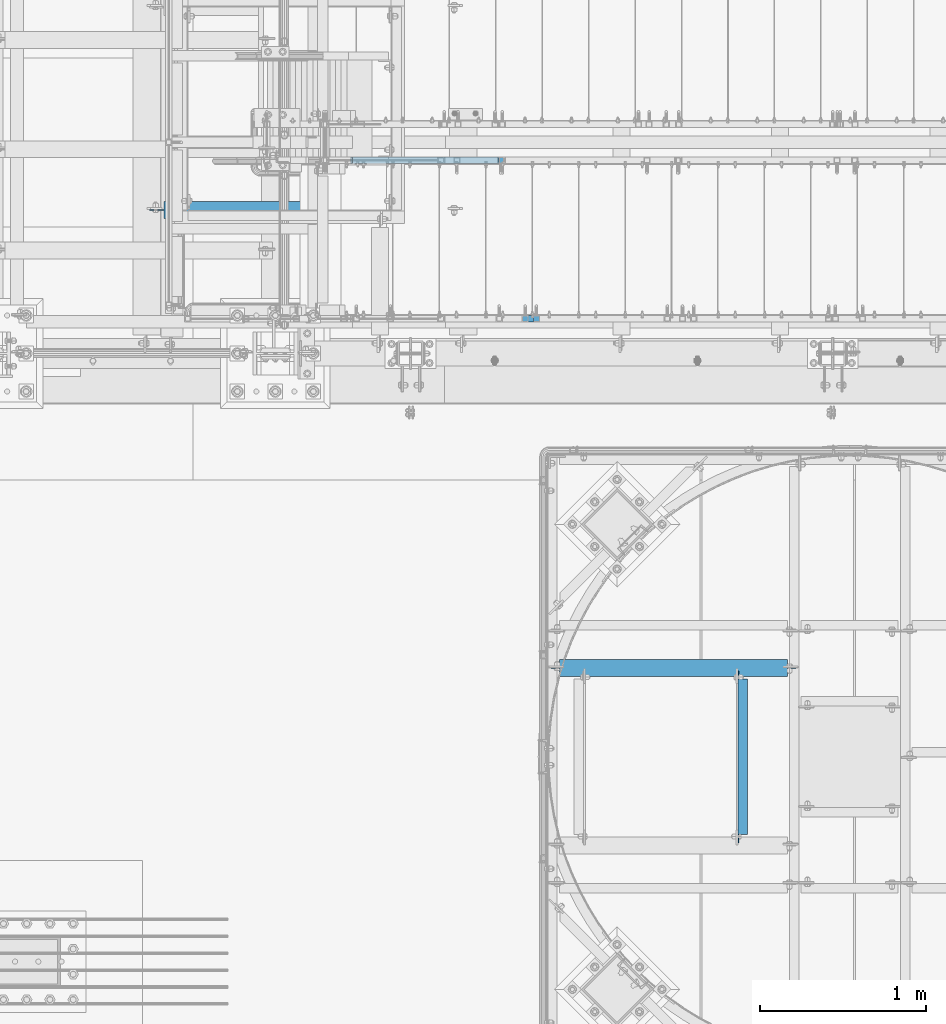
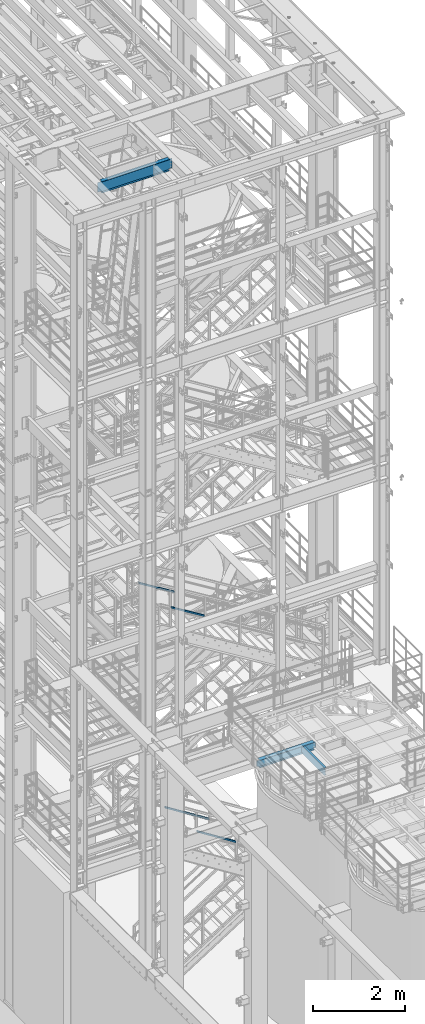
# One storey, part 937 of 1876: 4 members, 3 beams, 7 elements without a shape of their own.
"""IFC2X3 building model written with IfcOpenShell, lengths in millimetres."""

import ifcopenshell
import ifcopenshell.guid

model = None  # the IFC model being written
_history = None  # IfcOwnerHistory: only IFC2X3 demands one
_inside = {}  # id of a spatial element -> (the spatial element, [elements in it])
_under = {}  # id of a project, library or spatial element -> (it, [spatial elements below it])
_declared = {}  # id of a project -> (the project, [libraries it declares])
_typed = {}  # id of a type object -> (the type object, [elements of that type])
_made_of = {}  # id of a material, layer set ... -> (it, [elements and type objects made of it])


def new_model(schema):
    """Start an empty IFC model of exactly this schema.

    Asked for "IFC4X3", IfcOpenShell would pick the latest addendum, in which some entities
    have other attributes; the version numbers below select the first issue.
    IFC2X3 requires an IfcOwnerHistory on every rooted entity: one is made here for all.
    """
    global model, _history
    if schema == "IFC4X3":
        model = ifcopenshell.file(schema_version=(4, 3, 0, 0))
    else:
        model = ifcopenshell.file(schema=schema)
    _inside.clear()
    _under.clear()
    _declared.clear()
    _typed.clear()
    _made_of.clear()
    _history = None
    if model.schema == "IFC2X3":
        org = make("IfcOrganization", Name="unknown")
        user = make(
            "IfcPersonAndOrganization",
            ThePerson=make("IfcPerson", FamilyName="unknown"),
            TheOrganization=org,
        )
        app = make(
            "IfcApplication",
            ApplicationDeveloper=org,
            Version="unknown",
            ApplicationFullName="unknown",
            ApplicationIdentifier="unknown",
        )
        _history = make(
            "IfcOwnerHistory",
            OwningUser=user,
            OwningApplication=app,
            ChangeAction="ADDED",
            CreationDate=0,
        )
    return model


def make(cls, **values):
    """One entity of the class cls with the attributes given. An attribute that is None is left unset."""
    return model.create_entity(
        cls, **{name: value for name, value in values.items() if value is not None}
    )


def rooted(cls, **values):
    """An entity with a GlobalId (a new one), such as an element, a storey or a relation."""
    return make(cls, GlobalId=ifcopenshell.guid.new(), OwnerHistory=_history, **values)


def si_unit(unit_type, name, prefix=None):
    """IfcSIUnit, for example si_unit("LENGTHUNIT", "METRE", prefix="MILLI")."""
    return make("IfcSIUnit", UnitType=unit_type, Prefix=prefix, Name=name)


def assignment(units):
    """IfcUnitAssignment: the units of a project."""
    return None if units is None else make("IfcUnitAssignment", Units=units)


def point(xyz):
    """IfcCartesianPoint."""
    return None if xyz is None else make("IfcCartesianPoint", Coordinates=xyz)


def direction(xyz):
    """IfcDirection."""
    return None if xyz is None else make("IfcDirection", DirectionRatios=xyz)


def frame(location, z_axis=None, x_axis=None):
    """IfcAxis2Placement3D, a coordinate frame: its origin and axes. An axis left out is left unset."""
    return make(
        "IfcAxis2Placement3D",
        Location=point(location),
        Axis=direction(z_axis),
        RefDirection=direction(x_axis),
    )


def origin_with_axes():
    """The frame at (0, 0, 0) with the z axis (0, 0, 1) and the x axis (1, 0, 0) written out."""
    return frame((0.0, 0.0, 0.0), z_axis=(0.0, 0.0, 1.0), x_axis=(1.0, 0.0, 0.0))


def place(relative_to, where):
    """IfcLocalPlacement: puts the frame where relative to a parent placement (None: the world)."""
    return make(
        "IfcLocalPlacement", PlacementRelTo=relative_to, RelativePlacement=where
    )


def context(
    kind, dimensions, precision=None, world=None, true_north=None, identifier=None
):
    """IfcGeometricRepresentationContext, for example the 3D "Model" context."""
    return make(
        "IfcGeometricRepresentationContext",
        ContextIdentifier=identifier,
        ContextType=kind,
        CoordinateSpaceDimension=dimensions,
        Precision=precision,
        WorldCoordinateSystem=world,
        TrueNorth=true_north,
    )


def subcontext(parent, identifier, kind, view, scale=None):
    """IfcGeometricRepresentationSubContext, for example "Body" below "Model"."""
    return make(
        "IfcGeometricRepresentationSubContext",
        ContextIdentifier=identifier,
        ContextType=kind,
        ParentContext=parent,
        TargetScale=scale,
        TargetView=view,
    )


def project(units=None, contexts=None):
    """IfcProject with its units and contexts."""
    return rooted(
        "IfcProject",
        Name="project",
        RepresentationContexts=contexts,
        UnitsInContext=assignment(units),
    )


def spatial(cls, under=None, at=None, **own):
    """A site, building, storey or space (cls), placed at a placement, below another one or the project."""
    s = rooted(cls, ObjectPlacement=at, **own)
    if under is not None:
        _under.setdefault(under.id(), (under, []))[1].append(s)
    return s


def faces_of(points, faces, orient=None, outer=None):
    """IfcFace entities. A face is a list of loops; a loop is a list of indices into points, from 0.

    orient and outer hold one flag for each loop. By default every Orientation is true, the
    first loop of a face is its IfcFaceOuterBound and the others are IfcFaceBound.
    """
    made = []
    for i, loops in enumerate(faces):
        bounds = []
        for j, loop in enumerate(loops):
            is_outer = j == 0 if outer is None else outer[i][j]
            bounds.append(
                make(
                    "IfcFaceOuterBound" if is_outer else "IfcFaceBound",
                    Bound=make("IfcPolyLoop", Polygon=[points[k] for k in loop]),
                    Orientation=True if orient is None else orient[i][j],
                )
            )
        made.append(make("IfcFace", Bounds=bounds))
    return made


def faceted_brep(points, faces, orient=None, outer=None, voids=None):
    """IfcFacetedBrep: a solid bounded by flat faces; with voids (closed shells), ...WithVoids."""
    shared = [point(p) for p in points]
    hull = make("IfcClosedShell", CfsFaces=faces_of(shared, faces, orient, outer))
    if voids is None:
        return make("IfcFacetedBrep", Outer=hull)
    return make(
        "IfcFacetedBrepWithVoids",
        Outer=hull,
        Voids=[
            make(cls, CfsFaces=faces_of(shared, fs, o, b)) for cls, fs, o, b in voids
        ],
    )


def shape(context_of_items, identifier, shape_type, items):
    """IfcShapeRepresentation: the items that make up one representation, for example the "Body"."""
    return make(
        "IfcShapeRepresentation",
        ContextOfItems=context_of_items,
        RepresentationIdentifier=identifier,
        RepresentationType=shape_type,
        Items=items,
    )


def material(Name=None, Category=None):
    """IfcMaterial."""
    return make("IfcMaterial", Name=Name, Category=Category)


def made_of(thing, what):
    """Note that an element or type object is made of a material, layer set ...; save() writes the relation."""
    if what is not None:
        _made_of.setdefault(what.id(), (what, []))[1].append(thing)
    return thing


def type_object(cls, material=None, **own):
    """A type object (cls), such as IfcWallType, which elements share."""
    return made_of(rooted(cls, **own), material)


def element(
    cls,
    number,
    at=None,
    inside=None,
    cuts=None,
    type_object=None,
    material=None,
    context=None,
    identifier="Body",
    shape_type=None,
    held_by="IfcProductDefinitionShape",
    body=None,
    shapes=None,
    **own,
):
    """One element of the class cls, such as IfcWall. Its Tag is "e" and its number.

    at: its placement. inside: the storey or other place that contains it. cuts: it is an
    opening in that element (IfcRelVoidsElement). A single representation is given by context,
    identifier, shape_type and body (its items); several are given by shapes. held_by: the class
    of the entity that holds the representations. save() writes the other relations.
    """
    e = rooted(cls, Tag="e%d" % number, ObjectPlacement=at, **own)
    if body is not None:
        shapes = [shape(context, identifier, shape_type, body)]
    if shapes is not None:
        e.Representation = make(held_by, Representations=shapes)
    if inside is not None:
        _inside.setdefault(inside.id(), (inside, []))[1].append(e)
    if cuts is not None:
        rooted(
            "IfcRelVoidsElement", RelatingBuildingElement=cuts, RelatedOpeningElement=e
        )
    if type_object is not None:
        _typed.setdefault(type_object.id(), (type_object, []))[1].append(e)
    return made_of(e, material)


def aggregate(whole, parts):
    """IfcRelAggregates: a whole, such as a stair, and the parts it consists of."""
    return rooted("IfcRelAggregates", RelatingObject=whole, RelatedObjects=parts)


def save(model, path):
    """Write the relations noted so far, then the file.

    IfcRelAggregates (storeys below a building ...), IfcRelContainedInSpatialStructure (elements
    in a storey), IfcRelDefinesByType, IfcRelAssociatesMaterial and IfcRelDeclares: one each for
    every whole, place, type object, material and project.
    """
    for whole, parts in _under.values():
        aggregate(whole, parts)
    for where, things in _inside.values():
        rooted(
            "IfcRelContainedInSpatialStructure",
            RelatedElements=things,
            RelatingStructure=where,
        )
    for kind, things in _typed.values():
        rooted("IfcRelDefinesByType", RelatedObjects=things, RelatingType=kind)
    for what, things in _made_of.values():
        rooted("IfcRelAssociatesMaterial", RelatedObjects=things, RelatingMaterial=what)
    for by, libraries in _declared.values():
        rooted("IfcRelDeclares", RelatingContext=by, RelatedDefinitions=libraries)
    model.write(path)


model = new_model("IFC2X3")

# Units and contexts
model_context = context("Model", 3, precision=1e-05, world=origin_with_axes())
body_context = subcontext(model_context, "Body", "Model", "MODEL_VIEW")
ifc_project = project(units=[si_unit("LENGTHUNIT", "METRE", prefix="MILLI"), si_unit("AREAUNIT", "SQUARE_METRE"), si_unit("VOLUMEUNIT", "CUBIC_METRE"), si_unit("MASSUNIT", "GRAM", prefix="KILO"), si_unit("TIMEUNIT", "SECOND"), si_unit("PLANEANGLEUNIT", "RADIAN"), si_unit("SOLIDANGLEUNIT", "STERADIAN"), si_unit("THERMODYNAMICTEMPERATUREUNIT", "DEGREE_CELSIUS"), si_unit("LUMINOUSINTENSITYUNIT", "LUMEN")], contexts=[model_context])

# Site, building, storey
site_placement = place(None, origin_with_axes())
site = spatial("IfcSite", under=ifc_project, at=site_placement, CompositionType="ELEMENT")
building_placement = place(site_placement, origin_with_axes())
building = spatial("IfcBuilding", under=site, at=building_placement, Name="Undefined", CompositionType="ELEMENT")
storey_placement = place(building_placement, origin_with_axes())
storey = spatial("IfcBuildingStorey", under=building, at=storey_placement, Name="Undefined", CompositionType="ELEMENT", Elevation=0.0)

# Assembly, beam
assembly_1_placement = place(storey_placement, origin_with_axes())
assembly_1 = element("IfcElementAssembly", 1, at=assembly_1_placement, inside=storey, Name="BEAM", AssemblyPlace="NOTDEFINED", PredefinedType="RIGID_FRAME")
ifc_material_1 = material(Name="STEEL/A36")
beam_type_1 = type_object("IfcBeamType", Name="C8X11.5", PredefinedType="NOTDEFINED")
beam_1_placement = place(assembly_1_placement, frame((4537.07833884985, -10071.0643554687, 7896.225), z_axis=(0.0, 0.0, 1.0), x_axis=(0.0, 1.0, 0.0)))
beam_1 = element("IfcBeam", 2, at=beam_1_placement, type_object=beam_type_1, material=ifc_material_1, Name="BEAM", ObjectType="C8X11.5", context=body_context, shape_type="Brep", body=[
    faceted_brep([(15.875, 22.2250000000004, -76.1999999999989), (15.875, 28.5749999999998, -76.1999999999989), (53.9750001907378, 28.5749999999998, -76.1999999999989), (53.9750001907378, 22.2250000000004, -76.1999999999989), (58.8350797087842, 28.5749999999998, -77.1667299225865), (58.8350797087842, 22.2250000000004, -77.1667299225865), (62.9552561769378, 28.5749999999998, -79.9197438230649), (62.9552561769378, 22.2250000000004, -79.9197438230649), (65.7082700774154, 28.5749999999998, -84.0399202912186), (65.7082700774154, 22.2250000000004, -84.0399202912186), (66.6750000000029, 19.0576241940935, -88.899999809264), (66.6750000000029, 28.5749999999998, -88.899999809264), (66.6750000000029, 28.5749999999998, -101.6), (66.6750000000029, -28.5749999999998, -101.6), (66.6750000000029, -28.5749999999998, -96.8355949999996), (66.5700369653623, 22.2250000000004, -88.3723149999996), (1000.125, -28.5749999999998, -96.8355949999996), (1000.125, -28.5749999999998, -101.6), (1000.125, 28.5749999999998, -101.6), (1000.125, 28.5749999999998, -88.899999809264), (1000.125, 19.0576241940935, -88.899999809264), (1000.125, -28.5749999999998, 96.8355949999996), (1000.125, -28.5749999999998, 101.6), (66.6750000000029, -28.5749999999998, 101.6), (66.6750000000029, -28.5749999999998, 96.8355949999996), (1000.125, 19.0576241940826, 88.8999998092659), (1000.125, 28.5749999999998, 88.8999998092659), (1000.125, 28.5749999999998, 101.6), (66.6750000000029, 28.5749999999998, 101.6), (53.9750001907378, 22.2250000000004, 76.2000000000007), (53.9750001907378, 28.5749999999998, 76.2000000000007), (15.875, 28.5749999999998, 76.2000000000007), (15.875, 22.2250000000004, 76.2000000000007), (58.8350797087842, 22.2250000000004, 77.1667299225883), (58.8350797087842, 28.5749999999998, 77.1667299225883), (62.9552561769378, 22.2250000000004, 79.9197438230667), (62.9552561769378, 28.5749999999998, 79.9197438230667), (65.7082700774154, 22.2250000000004, 84.0399202912204), (65.7082700774154, 28.5749999999998, 84.0399202912204), (66.6750000000029, 19.0576241940826, 88.8999998092659), (66.6750000000029, 28.5749999999998, 88.8999998092659), (66.5700369653623, 22.2250000000004, 88.3723149999996), (1000.22996303464, 22.2250000000004, 88.3723149999996), (1001.09172992259, 22.2250000000004, 84.0399202912204), (1001.09172992259, 28.5749999999998, 84.0399202912204), (1003.84474382307, 22.2250000000004, 79.9197438230667), (1003.84474382307, 28.5749999999998, 79.9197438230667), (1007.96492029122, 22.2250000000004, 77.1667299225883), (1007.96492029122, 28.5749999999998, 77.1667299225883), (1012.82499980927, 22.2250000000004, 76.2000000000007), (1012.82499980927, 28.5749999999998, 76.2000000000007), (1050.925, 22.2250000000004, 76.2000000000007), (1050.925, 28.5749999999998, 76.2000000000007), (1050.925, 22.2250000000004, -76.1999999999989), (1050.925, 28.5749999999998, -76.1999999999989), (1012.82499980927, 22.2250000000004, -76.1999999999989), (1012.82499980927, 28.5749999999998, -76.1999999999989), (1007.96492029122, 22.2250000000004, -77.1667299225865), (1007.96492029122, 28.5749999999998, -77.1667299225865), (1003.84474382307, 22.2250000000004, -79.9197438230649), (1003.84474382307, 28.5749999999998, -79.9197438230649), (1001.09172992259, 22.2250000000004, -84.0399202912186), (1001.09172992259, 28.5749999999998, -84.0399202912186), (1000.22996303464, 22.2250000000004, -88.3723149999996)], [[[0, 1, 2, 3]], [[3, 2, 4, 5]], [[5, 4, 6, 7]], [[7, 6, 8, 9]], [[10, 11, 12, 13, 14]], [[15, 9, 8, 11, 10]], [[16, 17, 18, 19, 20]], [[21, 22, 23, 24]], [[22, 21, 25, 26, 27]], [[22, 27, 28, 23]], [[29, 30, 31, 32]], [[33, 34, 30, 29]], [[35, 36, 34, 33]], [[37, 38, 36, 35]], [[39, 40, 38, 37, 41]], [[23, 28, 40, 39, 24]], [[41, 42, 25, 21, 24, 39]], [[43, 44, 26, 25, 42]], [[45, 46, 44, 43]], [[47, 48, 46, 45]], [[49, 50, 48, 47]], [[51, 52, 50, 49]], [[52, 51, 53, 54]], [[53, 55, 56, 54]], [[57, 58, 56, 55]], [[59, 60, 58, 57]], [[61, 62, 60, 59]], [[63, 20, 19, 62, 61]], [[14, 16, 20, 63, 15, 10]], [[17, 16, 14, 13]], [[18, 17, 13, 12]], [[6, 4, 2, 1, 31, 30, 34, 36, 38, 40, 28, 27, 26, 44, 46, 48, 50, 52, 54, 56, 58, 60, 62, 19, 18, 12, 11, 8]], [[32, 31, 1, 0]], [[63, 61, 59, 57, 55, 53, 51, 49, 47, 45, 43, 42, 41, 37, 35, 33, 29, 32, 0, 3, 5, 7, 9, 15]]]),
])
aggregate(assembly_1, [beam_1])

assembly_2_placement = place(storey_placement, origin_with_axes())
assembly_2 = element("IfcElementAssembly", 3, at=assembly_2_placement, inside=storey, Name="BEAM", AssemblyPlace="NOTDEFINED", PredefinedType="RIGID_FRAME")
ifc_material_2 = material(Name="STEEL/A992")
beam_type_2 = type_object("IfcBeamType", Name="W8X13", PredefinedType="NOTDEFINED")
beam_2_placement = place(assembly_2_placement, frame((3365.50333884985, -9004.26435546873, 7896.225), z_axis=(0.0, 0.0, 1.0), x_axis=(1.0, 0.0, 0.0)))
beam_2 = element("IfcBeam", 4, at=beam_2_placement, type_object=beam_type_2, material=ifc_material_2, Name="BEAM", ObjectType="W8X13", context=body_context, shape_type="Brep", body=[
    faceted_brep([(1441.45000056773, -3.17499999999927, -95.25), (1441.45000056773, -50.7999999999993, -95.25), (1441.45000056773, -50.7999999999993, -101.6), (1441.45000056773, 50.7999999999993, -101.6), (1441.45000056773, 50.7999999999993, -95.25), (1441.45000056773, 3.17499999999927, -95.25), (1441.45000056773, 3.17499999999927, -89.1599998092661), (1441.45000056773, -3.17499999999927, -89.1599998092661), (1442.41673049032, 3.17499999999927, -84.2999202912206), (1442.41673049032, -3.17499999999927, -84.2999202912206), (1445.1697443908, 3.17499999999927, -80.1797438230669), (1445.1697443908, -3.17499999999927, -80.1797438230669), (1449.28992085895, 3.17499999999927, -77.4267299225885), (1449.28992085895, -3.17499999999927, -77.4267299225885), (1454.150000377, 3.17499999999927, -76.4600000000009), (1454.150000377, -3.17499999999927, -76.4600000000009), (1492.25, -3.17499999999927, -76.4600000000009), (1492.25, 3.17499999999927, -76.4600000000009), (69.8500006943577, 3.17500000000018, 95.25), (69.8500006943577, 50.8000000000002, 95.25), (1441.45000056773, 50.7999999999993, 95.25), (1441.45000056773, 3.17499999999927, 95.25), (69.849999432266, -3.17499999999927, -89.1599998092643), (69.849999432266, 3.17499999999927, -89.1599998092643), (69.849999432266, 3.17499999999927, -95.25), (69.849999432266, 50.7999999999993, -95.25), (69.849999432266, 50.7999999999993, -101.6), (69.849999432266, -50.7999999999993, -101.6), (69.849999432266, -50.7999999999993, -95.25), (69.849999432266, -3.17499999999927, -95.25), (68.883269509678, -3.17499999999927, -84.2999202912188), (68.883269509678, 3.17499999999927, -84.2999202912188), (66.1302556092, -3.17499999999927, -80.1797438230651), (66.1302556092, 3.17499999999927, -80.1797438230651), (62.0100791410464, -3.17499999999927, -77.4267299225867), (62.0100791410464, 3.17499999999927, -77.4267299225867), (57.1499996230009, -3.17499999999927, -76.4599999999991), (57.1499996230009, 3.17499999999927, -76.4599999999991), (19.0499999999997, -3.17499999999927, -76.4599999999991), (19.0499999999997, 3.17499999999927, -76.4599999999991), (19.0499999999997, -3.17499999999927, 75.9400016784675), (19.0499999999997, 3.17499999999927, 75.9400016784675), (57.1499996230009, -3.17499999999927, 75.9400016784675), (57.1499996230009, 3.17499999999927, 75.9400016784675), (62.0100791410464, -3.17499999999927, 76.9067316010551), (62.0100791410464, 3.17499999999927, 76.9067316010551), (66.1302556092, -3.17499999999927, 79.6597455015335), (66.1302556092, 3.17499999999927, 79.6597455015335), (68.883269509678, -3.17499999999927, 83.7799219696872), (68.883269509678, 3.17499999999927, 83.7799219696872), (69.849999432266, -3.17499999999927, 88.6400014877327), (69.849999432266, 3.17499999999927, 88.6400014877327), (69.849999432266, -50.7999999999993, 101.6), (69.849999432266, 50.7999999999993, 101.6), (69.8500006943577, -3.17500000000018, 95.25), (69.8500006943577, -50.8000000000002, 95.25), (1441.45000056773, -3.17499999999927, 95.25), (1441.45000056773, -50.7999999999993, 95.25), (1441.45000056773, -50.7999999999993, 101.6), (1441.45000056773, 50.7999999999993, 101.6), (1441.45000056773, -3.17499999999927, 88.6400014877308), (1441.45000056773, 3.17499999999927, 88.6400014877308), (1442.41673049032, -3.17499999999927, 83.7799219696853), (1442.41673049032, 3.17499999999927, 83.7799219696853), (1445.1697443908, -3.17499999999927, 79.6597455015317), (1445.1697443908, 3.17499999999927, 79.6597455015317), (1449.28992085895, -3.17499999999927, 76.9067316010533), (1449.28992085895, 3.17499999999927, 76.9067316010533), (1454.150000377, -3.17499999999927, 75.9400016784657), (1454.150000377, 3.17499999999927, 75.9400016784657), (1492.25, -3.17499999999927, 75.9400016784657), (1492.25, 3.17499999999927, 75.9400016784657)], [[[0, 1, 2, 3, 4, 5, 6, 7]], [[7, 6, 8, 9]], [[9, 8, 10, 11]], [[11, 10, 12, 13]], [[13, 12, 14, 15]], [[16, 15, 14, 17]], [[18, 19, 20, 21]], [[22, 23, 24, 25, 26, 27, 28, 29]], [[30, 31, 23, 22]], [[32, 33, 31, 30]], [[34, 35, 33, 32]], [[36, 37, 35, 34]], [[38, 39, 37, 36]], [[40, 41, 39, 38]], [[42, 43, 41, 40]], [[44, 45, 43, 42]], [[46, 47, 45, 44]], [[48, 49, 47, 46]], [[50, 51, 49, 48]], [[52, 53, 19, 18, 51, 50, 54, 55]], [[55, 54, 56, 57]], [[52, 55, 57, 58]], [[53, 52, 58, 59]], [[19, 53, 59, 20]], [[58, 57, 56, 60, 61, 21, 20, 59]], [[62, 63, 61, 60]], [[64, 65, 63, 62]], [[66, 67, 65, 64]], [[68, 69, 67, 66]], [[70, 71, 69, 68]], [[71, 70, 16, 17]], [[12, 10, 8, 6, 5, 24, 23, 31, 33, 35, 37, 39, 41, 43, 45, 47, 49, 51, 18, 21, 61, 63, 65, 67, 69, 71, 17, 14]], [[25, 24, 5, 4]], [[26, 25, 4, 3]], [[27, 26, 3, 2]], [[28, 27, 2, 1]], [[29, 28, 1, 0]], [[70, 68, 66, 64, 62, 60, 56, 54, 50, 48, 46, 44, 42, 40, 38, 36, 34, 32, 30, 22, 29, 0, 7, 9, 11, 13, 15, 16]]]),
])
aggregate(assembly_2, [beam_2])

assembly_3_placement = place(storey_placement, origin_with_axes())
assembly_3 = element("IfcElementAssembly", 5, at=assembly_3_placement, inside=storey, Name="BEAM", AssemblyPlace="NOTDEFINED", PredefinedType="RIGID_FRAME")
beam_type_3 = type_object("IfcBeamType", Name="W12X16", PredefinedType="NOTDEFINED")
beam_3_placement = place(assembly_3_placement, frame((949.325, -6248.4, 22402.8), z_axis=(0.0, 0.0, 1.0), x_axis=(1.0, 0.0, 0.0)))
beam_3 = element("IfcBeam", 6, at=beam_3_placement, type_object=beam_type_3, material=ifc_material_2, Name="BEAM", ObjectType="W12X16", context=body_context, shape_type="Brep", body=[
    faceted_brep([(19.84375, -3.17499999999995, -126.999999999996), (19.84375, 3.17499999999995, -126.999999999996), (96.0437501907345, 3.17500002364682, -126.999999999996), (96.0437501907345, -3.17499999999995, -126.999999999996), (100.90382970878, 3.17500002380461, -127.966729922584), (100.90382970878, -3.17499999999995, -127.966729922584), (105.024006176934, 3.17500002425209, -130.719743823061), (105.024006176934, -3.17499999999995, -130.719743823061), (107.777020077412, 3.17500002492102, -134.839920291215), (107.777020077412, -3.17499999999995, -134.839920291215), (108.74375, -3.17499999999995, -139.699999809261), (108.74375, 3.17500002570978, -139.699999809261), (108.74375, 3.17500009516311, -146.049999999999), (108.74375, 50.8, -146.049999999999), (108.74375, 50.8, -152.400000000001), (108.74375, -50.8, -152.400000000001), (108.74375, -50.8, -146.049999999999), (108.74375, -3.17499999999995, -146.049999999999), (1802.60625, 50.8000000000002, 146.049999999999), (1802.60625, 3.17500000000018, 146.049999999999), (108.74375, 3.17500000000018, 146.049999999999), (108.74375, 50.8000000000002, 146.049999999999), (96.043750190735, -3.17500000000018, 127.0), (96.043750190735, 3.17500000000018, 127.0), (19.8437500000002, 3.17500000000018, 127.0), (19.8437500000002, -3.17500000000018, 127.0), (100.90382970878, -3.17500000000018, 127.966729922588), (100.90382970878, 3.17500000000018, 127.966729922588), (105.024006176934, -3.17500000000018, 130.719743823065), (105.024006176934, 3.17500000000018, 130.719743823065), (107.777020077412, -3.17500000000018, 134.839920291219), (107.777020077412, 3.17500000000018, 134.839920291219), (108.74375, -3.17500000000018, 139.699999809265), (108.74375, 3.17500000000018, 139.699999809265), (1802.60625, -50.8000000000002, 152.400000000001), (1802.60625, 50.8000000000002, 152.400000000001), (108.74375, 50.8000000000002, 152.400000000001), (108.74375, -50.8000000000002, 152.400000000001), (1802.60625, -50.8000000000002, 146.049999999999), (108.74375, -50.8000000000002, 146.049999999999), (1802.60625, -3.17500000000018, 146.049999999999), (108.74375, -3.17500000000018, 146.049999999999), (1802.60625, -3.17500000000018, 139.699999809265), (1802.60625, 3.17500000000018, 139.699999809265), (1803.57297992259, -3.17500000000018, 134.839920291219), (1803.57297992259, 3.17500000000018, 134.839920291219), (1806.32599382307, -3.17500000000018, 130.719743823065), (1806.32599382307, 3.17500000000018, 130.719743823065), (1810.44617029122, -3.17500000000018, 127.966729922588), (1810.44617029122, 3.17500000000018, 127.966729922588), (1815.30624980927, -3.17500000000018, 127.0), (1815.30624980927, 3.17500000000018, 127.0), (1891.50625, -3.17500000000018, 127.0), (1891.50625, 3.17500000000018, 127.0), (1891.50625, -3.17500000000018, -127.0), (1891.50625, 3.17500000000018, -127.0), (1815.30624980927, -3.17500000000018, -127.0), (1815.30624980927, 3.17500000000018, -127.0), (1810.44617029122, -3.17500000000018, -127.966729922588), (1810.44617029122, 3.17500000000018, -127.966729922588), (1806.32599382307, -3.17500000000018, -130.719743823065), (1806.32599382307, 3.17500000000018, -130.719743823065), (1803.57297992259, -3.17500000000018, -134.839920291219), (1803.57297992259, 3.17500000000018, -134.839920291219), (1802.60625, -3.17500000000018, -139.699999809265), (1802.60625, 3.17500000000018, -139.699999809265), (1802.60625, -3.17500000000018, -146.049999999999), (1802.60625, -50.8000000000002, -146.049999999999), (1802.60625, -50.8000000000002, -152.400000000001), (1802.60625, 50.8000000000002, -152.400000000001), (1802.60625, 50.8000000000002, -146.049999999999), (1802.60625, 3.17500000000018, -146.049999999999)], [[[0, 1, 2, 3]], [[3, 2, 4, 5]], [[5, 4, 6, 7]], [[7, 6, 8, 9]], [[10, 11, 12, 13, 14, 15, 16, 17]], [[9, 8, 11, 10]], [[18, 19, 20, 21]], [[22, 23, 24, 25]], [[26, 27, 23, 22]], [[28, 29, 27, 26]], [[30, 31, 29, 28]], [[32, 33, 31, 30]], [[34, 35, 36, 37]], [[38, 34, 37, 39]], [[40, 38, 39, 41]], [[37, 36, 21, 20, 33, 32, 41, 39]], [[35, 18, 21, 36]], [[34, 38, 40, 42, 43, 19, 18, 35]], [[44, 45, 43, 42]], [[46, 47, 45, 44]], [[48, 49, 47, 46]], [[50, 51, 49, 48]], [[52, 53, 51, 50]], [[53, 52, 54, 55]], [[54, 56, 57, 55]], [[58, 59, 57, 56]], [[60, 61, 59, 58]], [[62, 63, 61, 60]], [[64, 65, 63, 62]], [[66, 67, 68, 69, 70, 71, 65, 64]], [[67, 66, 17, 16]], [[68, 67, 16, 15]], [[69, 68, 15, 14]], [[70, 69, 14, 13]], [[71, 70, 13, 12]], [[6, 4, 2, 1, 24, 23, 27, 29, 31, 33, 20, 19, 43, 45, 47, 49, 51, 53, 55, 57, 59, 61, 63, 65, 71, 12, 11, 8]], [[25, 24, 1, 0]], [[66, 64, 62, 60, 58, 56, 54, 52, 50, 48, 46, 44, 42, 40, 41, 32, 30, 28, 26, 22, 25, 0, 3, 5, 7, 9, 10, 17]]]),
])
aggregate(assembly_3, [beam_3])

# Assembly, member
assembly_4_placement = place(storey_placement, origin_with_axes())
assembly_4 = element("IfcElementAssembly", 7, at=assembly_4_placement, inside=storey, Name="RAIL", AssemblyPlace="NOTDEFINED", PredefinedType="RIGID_FRAME")
ifc_material_3 = material()
member_type = type_object("IfcMemberType", Name="HSS1-1/2X1-1/2X1/8", PredefinedType="NOTDEFINED")
member_1_placement = place(assembly_4_placement, frame((3962.40000306508, -5949.95000114554, 4368.5014111061), z_axis=(0.535697420207059, 0.0, 0.844410015326383), x_axis=(-0.844410015326383, 0.0, 0.535697420207059)))
member_1 = element("IfcMember", 8, at=member_1_placement, type_object=member_type, material=ifc_material_3, Name="RAIL", ObjectType="HSS1-1/2X1-1/2X1/8", context=body_context, shape_type="Brep", body=[
    faceted_brep([(10.4747262991696, -19.0499992349996, -19.0499992349991), (34.6455325374254, -19.0499992349996, 19.049999235012), (34.6455325374254, 19.0499992349996, 19.049999235012), (10.4747262991696, 19.0499992349996, -19.0499992349991), (32.6312986338025, 15.8749992829999, 15.8749992830109), (32.6312986338025, -15.8749992829999, 15.8749992830109), (12.4889602027924, -15.8749992829999, -15.8749992829981), (12.4889602027924, 15.8749992829999, -15.8749992829981), (1318.96228559638, 19.0499992349996, -19.0499992353589), (1318.96228559638, -19.0499992349996, -19.0499992353589), (1343.13309186325, -19.0499992349996, 19.0499992346431), (1343.13309186325, 19.0499992349996, 19.0499992346431), (1341.11885795724, -15.8749992829999, 15.8749992826424), (1341.11885795724, 15.8749992829999, 15.8749992826424), (1320.97651950239, 15.8749992829999, -15.8749992833582), (1320.97651950239, -15.8749992829999, -15.8749992833582)], [[[0, 1, 2, 3], [4, 5, 6, 7]], [[8, 9, 0, 3]], [[9, 10, 1, 0]], [[10, 11, 2, 1]], [[11, 8, 3, 2]], [[10, 9, 8, 11], [12, 13, 14, 15]], [[13, 12, 5, 4]], [[14, 13, 4, 7]], [[15, 14, 7, 6]], [[12, 15, 6, 5]]]),
])
aggregate(assembly_4, [member_1])

assembly_5_placement = place(storey_placement, origin_with_axes())
assembly_5 = element("IfcElementAssembly", 9, at=assembly_5_placement, inside=storey, Name="RAIL", AssemblyPlace="NOTDEFINED", PredefinedType="RIGID_FRAME")
member_2_placement = place(assembly_5_placement, frame((4084.63750452111, -6902.45000114554, 4300.47840362814), z_axis=(0.535697420207059, 0.0, 0.844410015326383), x_axis=(-0.844410015326383, 0.0, 0.535697420207059)))
member_2 = element("IfcMember", 10, at=member_2_placement, type_object=member_type, material=ifc_material_3, Name="RAIL", ObjectType="HSS1-1/2X1-1/2X1/8", context=body_context, shape_type="Brep", body=[
    faceted_brep([(10.4747262991696, -19.0499992349996, -19.0499992349991), (34.6455325374254, -19.0499992349996, 19.049999235012), (34.6455325374254, 19.0499992349996, 19.049999235012), (10.4747262991696, 19.0499992349996, -19.0499992349991), (32.6312986338025, 15.8749992829999, 15.8749992830109), (32.6312986338025, -15.8749992829999, 15.8749992830109), (12.4889602027924, -15.8749992829999, -15.8749992829981), (12.4889602027924, 15.8749992829999, -15.8749992829981), (1162.92138404577, 19.0499992349996, -19.0499992353161), (1162.92138404577, -19.0499992349996, -19.0499992353161), (1187.09219031264, -19.0499992349996, 19.0499992346859), (1187.09219031264, 19.0499992349996, 19.0499992346859), (1185.07795640663, -15.8749992829999, 15.8749992826852), (1185.07795640663, 15.8749992829999, 15.8749992826852), (1164.93561795178, 15.8749992829999, -15.8749992833154), (1164.93561795178, -15.8749992829999, -15.8749992833154)], [[[0, 1, 2, 3], [4, 5, 6, 7]], [[8, 9, 0, 3]], [[9, 10, 1, 0]], [[10, 11, 2, 1]], [[11, 8, 3, 2]], [[10, 9, 8, 11], [12, 13, 14, 15]], [[13, 12, 5, 4]], [[14, 13, 4, 7]], [[15, 14, 7, 6]], [[12, 15, 6, 5]]]),
])
aggregate(assembly_5, [member_2])

assembly_6_placement = place(storey_placement, origin_with_axes())
assembly_6 = element("IfcElementAssembly", 11, at=assembly_6_placement, inside=storey, Name="RAIL", AssemblyPlace="NOTDEFINED", PredefinedType="RIGID_FRAME")
member_3_placement = place(assembly_6_placement, frame((3297.76666731675, -6902.45000114554, 10589.5459546993), z_axis=(0.523955482879573, 0.0, 0.851745649804232), x_axis=(-0.851745649804232, 0.0, 0.523955482879573)))
member_3 = element("IfcMember", 12, at=member_3_placement, type_object=member_type, material=ifc_material_3, Name="RAIL", ObjectType="HSS1-1/2X1-1/2X1/8", context=body_context, shape_type="Brep", body=[
    faceted_brep([(10.6471616099025, -19.0499992349996, -19.0499992350033), (34.0845307397099, -19.0499992349996, 19.0499992350287), (34.0845307397099, 19.0499992349996, 19.0499992350287), (10.6471616099025, 19.0499992349996, -19.0499992350033), (32.1314140629433, 15.8749992829999, 15.8749992830271), (32.1314140629433, -15.8749992829999, 15.8749992830271), (12.6002676416374, -15.8749992829999, -15.8749992830035), (12.6002676416374, 15.8749992829999, -15.8749992830035), (997.228827561887, 19.0499992349996, -19.0499992343539), (997.228827561887, -19.0499992349996, -19.0499992343539), (1020.66622709623, -19.0499992349996, 19.0499992356781), (1020.66622709623, 19.0499992349996, 19.0499992356781), (1018.71311041946, -15.8749992829999, 15.8749992836765), (1018.71311041946, 15.8749992829999, 15.8749992836765), (999.181944238654, 15.8749992829999, -15.8749992823523), (999.181944238654, -15.8749992829999, -15.8749992823523)], [[[0, 1, 2, 3], [4, 5, 6, 7]], [[8, 9, 0, 3]], [[9, 10, 1, 0]], [[10, 11, 2, 1]], [[11, 8, 3, 2]], [[10, 9, 8, 11], [12, 13, 14, 15]], [[13, 12, 5, 4]], [[14, 13, 4, 7]], [[15, 14, 7, 6]], [[12, 15, 6, 5]]]),
])
aggregate(assembly_6, [member_3])

assembly_7_placement = place(storey_placement, origin_with_axes())
assembly_7 = element("IfcElementAssembly", 13, at=assembly_7_placement, inside=storey, Name="RAIL", AssemblyPlace="NOTDEFINED", PredefinedType="RIGID_FRAME")
member_4_placement = place(assembly_7_placement, frame((3092.45000068741, -5949.95000114554, 10715.8475016834), z_axis=(0.523955482879573, 0.0, 0.851745649804232), x_axis=(-0.851745649804232, 0.0, 0.523955482879573)))
member_4 = element("IfcMember", 14, at=member_4_placement, type_object=member_type, material=ifc_material_3, Name="RAIL", ObjectType="HSS1-1/2X1-1/2X1/8", context=body_context, shape_type="Brep", body=[
    faceted_brep([(12.6002676416374, 15.8749992829999, -15.8749992830035), (12.6002676416374, -15.8749992829999, -15.8749992830035), (1061.58629453264, -15.8749992829999, -15.8749992823123), (1061.58629453264, 15.8749992829999, -15.8749992823123), (32.1314140629433, -15.8749992829999, 15.8749992830271), (1070.57002609866, -15.8749992829999, 15.8749992837093), (32.1314140629433, 15.8749992829999, 15.8749992830271), (1070.57002609866, 15.8749992829999, 15.8749992837093), (10.6471616099025, 19.0499992349996, -19.0499992350033), (34.0845307397099, 19.0499992349996, 19.0499992350287), (1071.46839928226, 19.0499992349996, 19.049999235709), (1060.68792134905, 19.0499992349996, -19.0499992343139), (34.0845307397099, -19.0499992349996, 19.0499992350287), (1071.46839928226, -19.0499992349996, 19.049999235709), (10.6471616099025, -19.0499992349996, -19.0499992350033), (1060.68792134905, -19.0499992349996, -19.0499992343139)], [[[0, 1, 2, 3]], [[1, 4, 5, 2]], [[4, 6, 7, 5]], [[6, 0, 3, 7]], [[8, 9, 10, 11]], [[9, 12, 13, 10]], [[12, 14, 15, 13]], [[14, 8, 11, 15]], [[13, 15, 11, 10], [5, 7, 3, 2]], [[14, 12, 9, 8], [6, 4, 1, 0]]]),
])
aggregate(assembly_7, [member_4])

save(model, "model.ifc")
